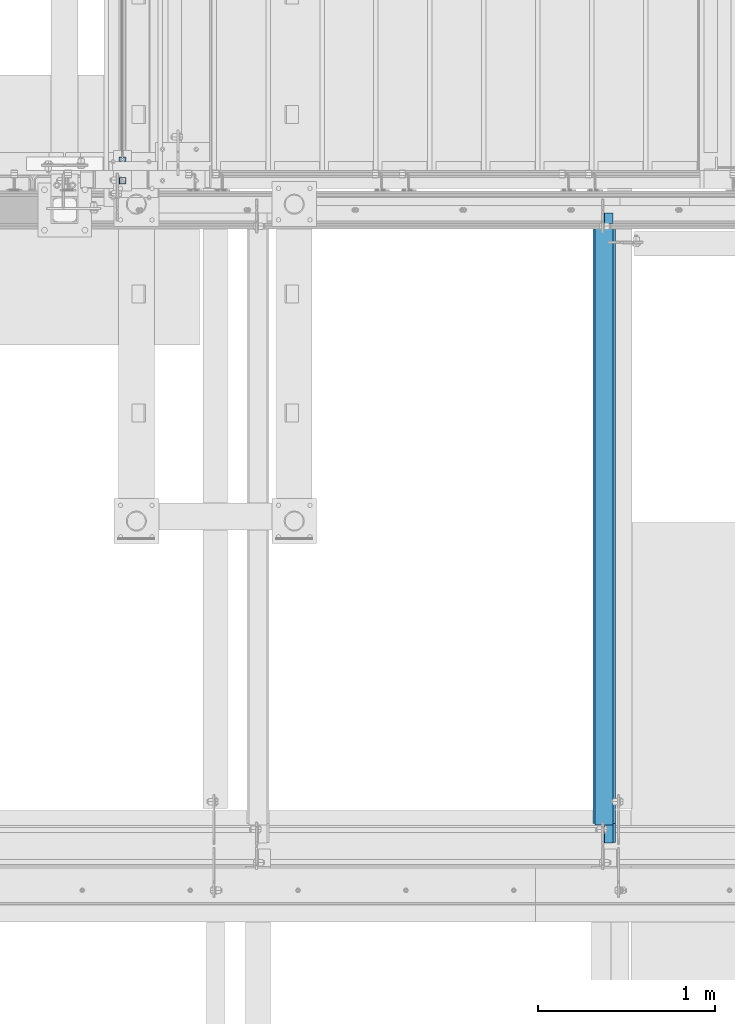
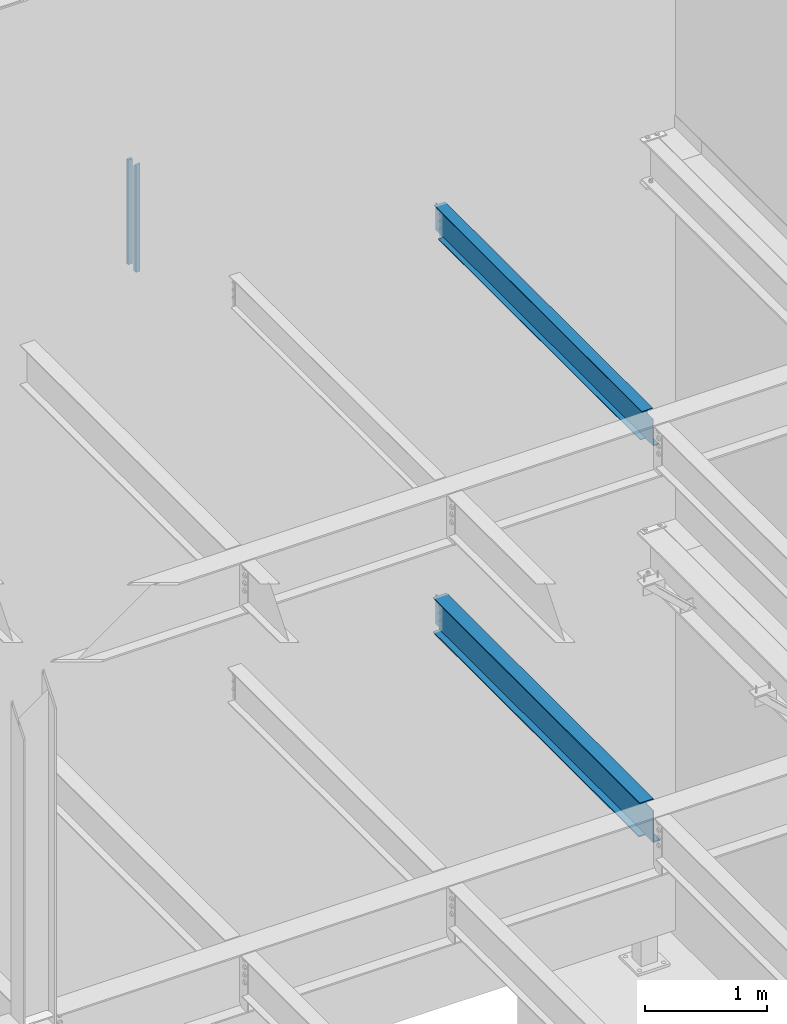
# One storey, part 777 of 1179: 2 beams, 2 members, 3 elements without a shape of their own.
"""IFC2X3 building model written with IfcOpenShell, lengths in millimetres."""

from ifc_helpers import new_model, si_unit, frame, origin_with_axes, place, context, subcontext, project, spatial, faceted_brep, material, type_object, element, aggregate, save


model = new_model("IFC2X3")

# Units and contexts
model_context = context("Model", 3, precision=1e-05, world=origin_with_axes())
body_context = subcontext(model_context, "Body", "Model", "MODEL_VIEW")
ifc_project = project(units=[si_unit("LENGTHUNIT", "METRE", prefix="MILLI"), si_unit("AREAUNIT", "SQUARE_METRE"), si_unit("VOLUMEUNIT", "CUBIC_METRE"), si_unit("MASSUNIT", "GRAM", prefix="KILO"), si_unit("TIMEUNIT", "SECOND"), si_unit("PLANEANGLEUNIT", "RADIAN"), si_unit("SOLIDANGLEUNIT", "STERADIAN"), si_unit("THERMODYNAMICTEMPERATUREUNIT", "DEGREE_CELSIUS"), si_unit("LUMINOUSINTENSITYUNIT", "LUMEN")], contexts=[model_context])

# Site, building, storey
site_placement = place(None, origin_with_axes())
site = spatial("IfcSite", under=ifc_project, at=site_placement, CompositionType="ELEMENT")
building_placement = place(site_placement, origin_with_axes())
building = spatial("IfcBuilding", under=site, at=building_placement, Name="Undefined", CompositionType="ELEMENT")
storey_placement = place(building_placement, origin_with_axes())
storey = spatial("IfcBuildingStorey", under=building, at=storey_placement, Name="Undefined", CompositionType="ELEMENT", Elevation=0.0)

# Assembly, members
assembly_1_placement = place(storey_placement, origin_with_axes())
assembly_1 = element("IfcElementAssembly", 1, at=assembly_1_placement, inside=storey, Name="GUARDRAIL", AssemblyPlace="NOTDEFINED", PredefinedType="RIGID_FRAME")
ifc_material_1 = material(Name="STEEL/A36")
member_type_1 = type_object("IfcMemberType", PredefinedType="NOTDEFINED")
member_1_placement = place(assembly_1_placement, frame((19605.6249999269, 38271.44999847, 8147.05), z_axis=(-1.0, 0.0, 0.0), x_axis=(0.0, 0.0, 1.0)))
member_1 = element("IfcMember", 2, at=member_1_placement, type_object=member_type_1, material=ifc_material_1, Name="POST", context=body_context, shape_type="Brep", body=[
    faceted_brep([(1047.75000059595, -12.6999999999971, 19.0499999999993), (1047.75000059595, -12.6999999999971, -19.0499999999993), (1047.75000059595, 12.6999999999971, -19.0499999999993), (1047.75000059595, 12.6999999999971, 19.0499999999993), (0.0, -12.7000000000007, -19.0500000000029), (0.0, -12.7000000000007, 19.0500000000029), (0.0, 12.7000000000007, 19.0500000000029), (0.0, 12.7000000000007, -19.0500000000029)], [[[0, 1, 2, 3]], [[4, 5, 6, 7]], [[6, 5, 0, 3]], [[7, 6, 3, 2]], [[4, 7, 2, 1]], [[5, 4, 1, 0]]]),
])
ifc_material_2 = material()
member_type_2 = type_object("IfcMemberType", Name="HSS1-1/2X1-1/2X1/8", PredefinedType="NOTDEFINED")
member_2_placement = place(assembly_1_placement, frame((19605.6249999269, 38150.799999235, 8147.05), z_axis=(-1.0, 0.0, 0.0), x_axis=(0.0, 0.0, 1.0)))
member_2 = element("IfcMember", 3, at=member_2_placement, type_object=member_type_2, material=ifc_material_2, Name="POST", ObjectType="HSS1-1/2X1-1/2X1/8", context=body_context, shape_type="Brep", body=[
    faceted_brep([(0.0, 15.8749992830017, -15.8749992829999), (0.0, -15.8749992830017, -15.8749992829999), (1082.67499987895, -15.874999282998, -15.8749992830017), (1050.92500131295, 15.874999282998, -15.8749992830017), (0.0, -15.8749992830017, 15.8749992829999), (1082.67499987895, -15.874999282998, 15.8749992830017), (0.0, 15.8749992830017, 15.8749992829999), (1050.92500131295, 15.874999282998, 15.8749992830017), (0.0, 19.0499992350015, -19.0499992349996), (0.0, 19.0499992350015, 19.0499992349996), (1047.74999838855, 19.0499992350015, 19.0499992350015), (1047.74999838855, 19.0499992350015, -19.0499992350015), (0.0, -19.0499992350015, 19.0499992349996), (1085.84999983095, -19.0499992350015, 19.0499992350015), (0.0, -19.0499992350015, -19.0499992349996), (1085.84999983095, -19.0499992350015, -19.0499992350015)], [[[0, 1, 2, 3]], [[1, 4, 5, 2]], [[4, 6, 7, 5]], [[6, 0, 3, 7]], [[8, 9, 10, 11]], [[9, 12, 13, 10]], [[12, 14, 15, 13]], [[14, 8, 11, 15]], [[13, 15, 11, 10], [5, 7, 3, 2]], [[14, 12, 9, 8], [6, 4, 1, 0]]]),
])
aggregate(assembly_1, [member_1, member_2])

# Assembly, beam
assembly_2_placement = place(storey_placement, origin_with_axes())
assembly_2 = element("IfcElementAssembly", 4, at=assembly_2_placement, inside=storey, Name="BEAM", AssemblyPlace="NOTDEFINED", PredefinedType="RIGID_FRAME")
ifc_material_3 = material(Name="STEEL/A992")
beam_type_1 = type_object("IfcBeamType", Name="W12X14", PredefinedType="NOTDEFINED")
beam_1_placement = place(assembly_2_placement, frame((22326.6, 34391.6, 7862.8875), z_axis=(0.0, 0.0, 1.0), x_axis=(0.0, 1.0, 0.0)))
beam_1 = element("IfcBeam", 5, at=beam_1_placement, type_object=beam_type_1, material=ifc_material_3, Name="BEAM", ObjectType="W12X14", context=body_context, shape_type="Brep", body=[
    faceted_brep([(104.775000190733, -2.38124999999854, 115.8875), (104.775000190733, 2.38123168416132, 115.8875), (17.4624999999942, 2.38124999999854, 115.8875), (17.4624999999942, -2.38124999999854, 115.8875), (109.63507970878, -2.38124999999854, 116.854229922587), (109.63507970878, 2.38123087677377, 116.854229922587), (113.755256176933, -2.38124999999854, 119.607243823066), (113.755256176933, 2.38122857751659, 119.607243823066), (116.508270077407, -2.38124999999854, 123.727420291219), (116.508270077407, 2.38122513643975, 123.727420291219), (117.474999999999, -2.38124999999854, 128.587499809265), (117.474999999999, 2.38122107741219, 128.587499809265), (117.474999999999, -50.7999999999993, 150.8125), (117.474999999999, 50.7999999999993, 150.8125), (117.474999999999, 50.7999999999993, 144.4625), (117.474999999999, 2.38124999999854, 144.4625), (117.474999999999, -2.38124999999854, 144.4625), (117.474999999999, -50.7999999999993, 144.4625), (3451.22500000001, 2.38124999999854, -144.4625), (3451.22500000001, 50.7999999999993, -144.4625), (144.462499999994, 50.7999999999993, -144.4625), (144.462499999994, 2.38174991607593, -144.4625), (17.4624999999942, -2.38124999999854, -144.4625), (17.4624999999942, -50.7999999999993, -144.4625), (3578.22500000001, -50.7999999999993, -144.4625), (3578.22500000001, -2.38124999999854, -144.4625), (17.4624999999942, -50.7999999999993, -150.8125), (3578.22500000001, -50.7999999999993, -150.8125), (3451.22500000001, 50.7999999999993, -150.8125), (3451.22500000001, 2.38186894147293, -150.8125), (3578.22500000001, 2.38186894147293, -150.8125), (17.4624999999942, 2.38174991607593, -150.8125), (144.462499999994, 2.38174991607593, -150.8125), (144.462499999994, 50.7999999999993, -150.8125), (17.4624999999942, 2.38124999999854, -144.4625), (3578.22500000001, 2.38124999999854, -144.4625), (3578.22500000001, 2.38124999999854, 125.4125), (3578.22500000001, -2.38124999999854, 125.4125), (3530.59999980927, 2.38124999999854, 125.4125), (3530.59999980927, -2.38124999999854, 125.4125), (3525.73992029123, 2.38124999999854, 126.379229922588), (3525.73992029123, -2.38124999999854, 126.379229922588), (3521.61974382307, 2.38124999999854, 129.132243823066), (3521.61974382307, -2.38124999999854, 129.132243823066), (3518.8667299226, 2.38124999999854, 133.25242029122), (3518.8667299226, -2.38124999999854, 133.25242029122), (3517.90000000001, 2.38124999999854, 138.112499809266), (3517.90000000001, -2.38124999999854, 138.112499809266), (3517.90000000001, -50.7999999999993, 150.8125), (3517.90000000001, -50.7999999999993, 144.4625), (3517.90000000001, -2.38124999999854, 144.4625), (3517.90000000001, 2.38124999999854, 144.4625), (3517.90000000001, 50.7999999999993, 144.4625), (3517.90000000001, 50.7999999999993, 150.8125)], [[[0, 1, 2, 3]], [[4, 5, 1, 0]], [[6, 7, 5, 4]], [[8, 9, 7, 6]], [[10, 11, 9, 8]], [[12, 13, 14, 15, 11, 10, 16, 17]], [[18, 19, 20, 21]], [[22, 23, 24, 25]], [[23, 26, 27, 24]], [[28, 29, 30, 27, 26, 31, 32, 33]], [[21, 32, 31, 34]], [[20, 33, 32, 21]], [[19, 28, 33, 20]], [[18, 29, 28, 19]], [[35, 30, 29, 18]], [[25, 24, 27, 30, 35, 36, 37]], [[37, 36, 38, 39]], [[39, 38, 40, 41]], [[41, 40, 42, 43]], [[43, 42, 44, 45]], [[45, 44, 46, 47]], [[48, 49, 50, 47, 46, 51, 52, 53]], [[49, 48, 12, 17]], [[50, 49, 17, 16]], [[8, 6, 4, 0, 3, 22, 25, 37, 39, 41, 43, 45, 47, 50, 16, 10]], [[34, 31, 26, 23, 22, 3, 2]], [[51, 46, 44, 42, 40, 38, 36, 35, 18, 21, 34, 2, 1, 5, 7, 9, 11, 15]], [[52, 51, 15, 14]], [[53, 52, 14, 13]], [[48, 53, 13, 12]]]),
])
aggregate(assembly_2, [beam_1])

assembly_3_placement = place(storey_placement, origin_with_axes())
assembly_3 = element("IfcElementAssembly", 6, at=assembly_3_placement, inside=storey, Name="BEAM", AssemblyPlace="NOTDEFINED", PredefinedType="RIGID_FRAME")
beam_type_2 = type_object("IfcBeamType", Name="W14X26", PredefinedType="NOTDEFINED")
beam_2_placement = place(assembly_3_placement, frame((22326.6, 34391.6, 3925.8875), z_axis=(0.0, 0.0, 1.0), x_axis=(0.0, 1.0, 0.0)))
beam_2 = element("IfcBeam", 7, at=beam_2_placement, type_object=beam_type_2, material=ifc_material_3, Name="BEAM", ObjectType="W14X26", context=body_context, shape_type="Brep", body=[
    faceted_brep([(115.093750190732, -3.17499999999927, 144.462500000001), (115.093750190732, 3.17491991689894, 144.462500000001), (18.2562499999985, 3.17499999999927, 144.462500000001), (18.2562499999985, -3.17499999999927, 144.462500000001), (119.953829708778, -3.17499999999927, 145.429229922589), (119.953829708778, 3.17491919624808, 145.429229922589), (124.074006176932, -3.17499999999927, 148.182243823067), (124.074006176932, 3.17491714401331, 148.182243823067), (126.827020077406, -3.17499999999927, 152.30242029122), (126.827020077406, 3.17491407262423, 152.30242029122), (127.793749999997, -3.17499999999927, 157.162499809266), (127.793749999997, 3.17491044967755, 157.162499809266), (127.793749999997, -63.5, 176.2125), (127.793749999997, 63.5, 176.2125), (127.793749999997, 63.5, 165.1), (127.793749999997, 3.17499999999927, 165.1), (127.793749999997, -3.17499999999927, 165.1), (127.793749999997, -63.5, 165.1), (3517.90000000001, 63.5, -165.1), (3517.90000000001, 63.5, -176.2125), (145.256249999999, 63.5, -176.2125), (145.256249999999, 63.5, -165.1), (18.2562499999985, -3.17499999999927, -165.1), (18.2562499999985, -63.5, -165.1), (3517.90000000001, -63.5, -165.1), (3517.90000000001, -3.17499999999927, -165.1), (18.2562499999985, -63.5, -176.2125), (3517.90000000001, -63.5, -176.2125), (18.2562499999985, 3.17549991607666, -176.2125), (145.256249999999, 3.17549991607666, -176.2125), (145.256249999999, 3.17549991607666, -165.1), (18.2562499999985, 3.17499999999927, -165.1), (3517.90000000001, 3.17499999999927, -165.1), (3517.90000000001, 3.17499999999927, -160.337499809265), (3517.90000000001, -3.17499999999927, -160.337499809265), (3518.8667299226, 3.17499999999927, -155.47742029122), (3518.8667299226, -3.17499999999927, -155.47742029122), (3521.61974382307, 3.17499999999927, -151.357243823066), (3521.61974382307, -3.17499999999927, -151.357243823066), (3525.73992029123, 3.17499999999927, -148.604229922588), (3525.73992029123, -3.17499999999927, -148.604229922588), (3530.59999980927, 3.17499999999927, -147.6375), (3530.59999980927, -3.17499999999927, -147.6375), (3578.22500000001, -3.17499999999927, -147.6375), (3578.22500000001, 3.17499999999927, -147.6375), (3578.22500000001, 3.17499999999927, 147.6375), (3578.22500000001, -3.17499999999927, 147.6375), (3530.59999980927, 3.17499999999927, 147.6375), (3530.59999980927, -3.17499999999927, 147.6375), (3525.73992029123, 3.17499999999927, 148.604229922588), (3525.73992029123, -3.17499999999927, 148.604229922588), (3521.61974382307, 3.17499999999927, 151.357243823066), (3521.61974382307, -3.17499999999927, 151.357243823066), (3518.8667299226, 3.17499999999927, 155.477420291219), (3518.8667299226, -3.17499999999927, 155.477420291219), (3517.90000000001, 3.17499999999927, 160.337499809265), (3517.90000000001, -3.17499999999927, 160.337499809265), (3517.90000000001, -63.5, 176.2125), (3517.90000000001, -63.5, 165.1), (3517.90000000001, -3.17499999999927, 165.1), (3517.90000000001, 3.17499999999927, 165.1), (3517.90000000001, 63.5, 165.1), (3517.90000000001, 63.5, 176.2125)], [[[0, 1, 2, 3]], [[4, 5, 1, 0]], [[6, 7, 5, 4]], [[8, 9, 7, 6]], [[10, 11, 9, 8]], [[12, 13, 14, 15, 11, 10, 16, 17]], [[18, 19, 20, 21]], [[22, 23, 24, 25]], [[23, 26, 27, 24]], [[19, 27, 26, 28, 29, 20]], [[30, 29, 28, 31]], [[21, 20, 29, 30]], [[32, 18, 21, 30]], [[25, 24, 27, 19, 18, 32, 33, 34]], [[34, 33, 35, 36]], [[36, 35, 37, 38]], [[38, 37, 39, 40]], [[40, 39, 41, 42]], [[43, 42, 41, 44]], [[45, 46, 43, 44]], [[46, 45, 47, 48]], [[48, 47, 49, 50]], [[50, 49, 51, 52]], [[52, 51, 53, 54]], [[54, 53, 55, 56]], [[57, 58, 59, 56, 55, 60, 61, 62]], [[58, 57, 12, 17]], [[59, 58, 17, 16]], [[8, 6, 4, 0, 3, 22, 25, 34, 36, 38, 40, 42, 43, 46, 48, 50, 52, 54, 56, 59, 16, 10]], [[31, 28, 26, 23, 22, 3, 2]], [[60, 55, 53, 51, 49, 47, 45, 44, 41, 39, 37, 35, 33, 32, 30, 31, 2, 1, 5, 7, 9, 11, 15]], [[61, 60, 15, 14]], [[62, 61, 14, 13]], [[57, 62, 13, 12]]]),
])
aggregate(assembly_3, [beam_2])

save(model, "model.ifc")
